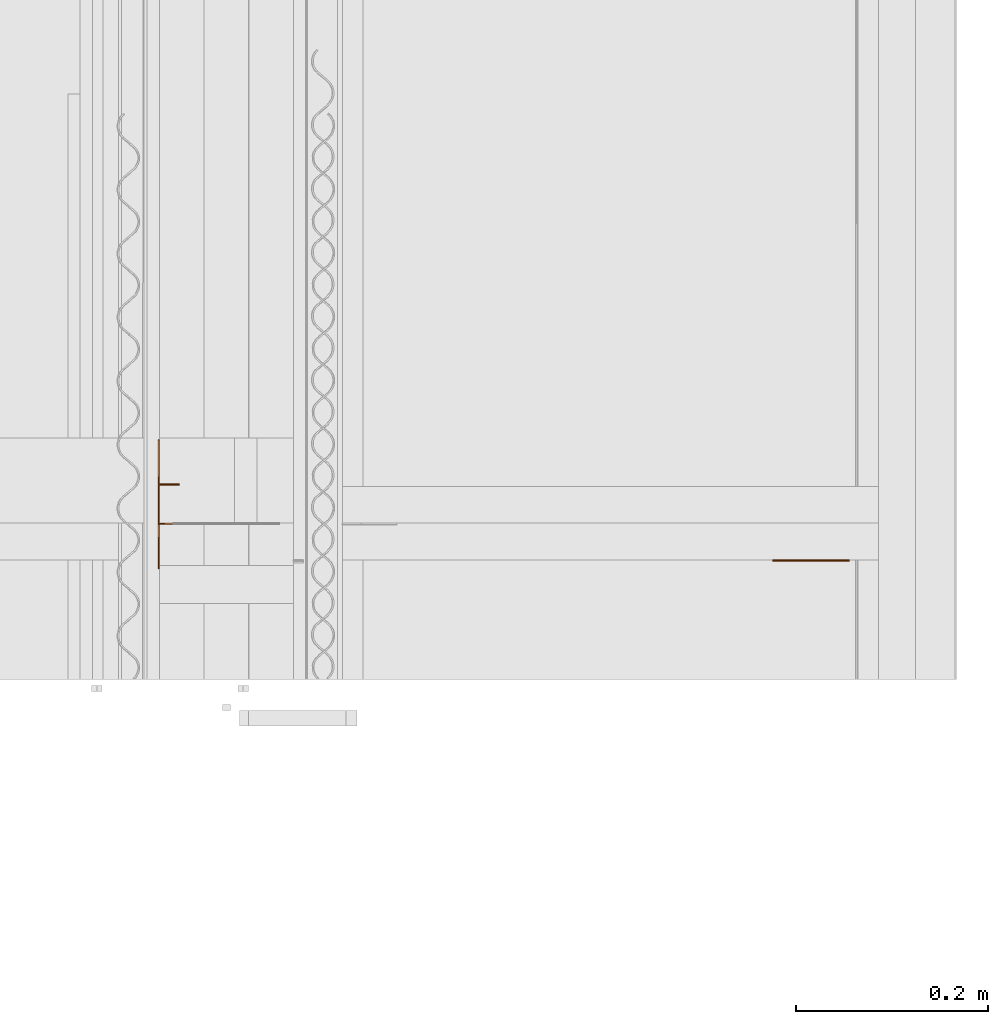
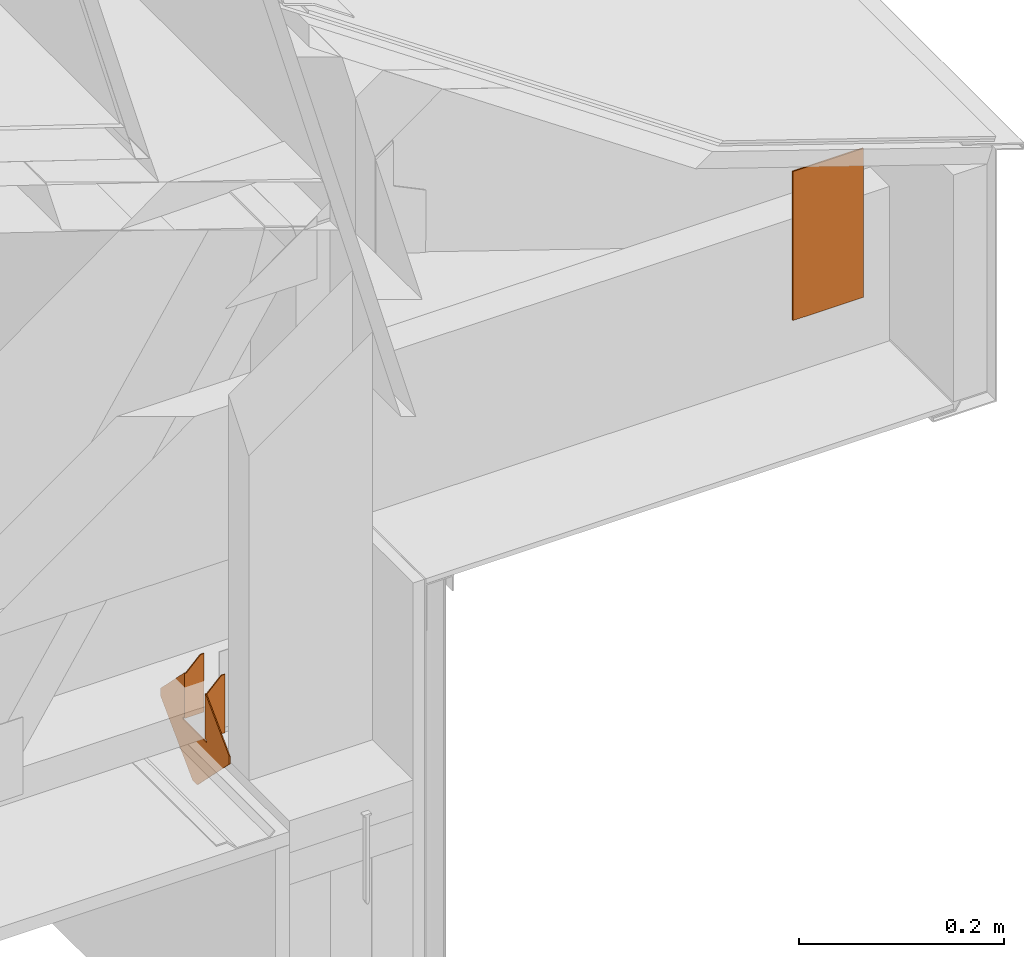
# One storey, part 21 of 22: 2 proxies.
"""IFC2X3 building model written with IfcOpenShell, lengths in feet."""

from ifc_helpers import new_model, entity, si_unit, converted_unit, frame, frame_2d, origin_with_axes, place, context, subcontext, project, spatial, faceted_brep, element, save


model = new_model("IFC2X3")

# Units and contexts
model_context = context("Model", 3, precision=1e-05)
plan_context = context("Plan", 2, precision=1e-05, world=frame_2d((0.0, 0.0, 0.0), x_axis=(1.0, 0.0, 0.0)))
body_context_1 = subcontext(model_context, "Body", "Model", "MODEL_VIEW")
body_context_2 = subcontext(model_context, "Body", "Model", "MODEL_VIEW")
ifc_project = project(units=[converted_unit("VOLUMEUNIT", "cubic foot", entity("IfcReal", 0.0283168467116885), si_unit("VOLUMEUNIT", "CUBIC_METRE"), dimensions=[3, 0, 0, 0, 0, 0, 0]), converted_unit("AREAUNIT", "square foot", entity("IfcReal", 0.09290304), si_unit("AREAUNIT", "SQUARE_METRE"), dimensions=[2, 0, 0, 0, 0, 0, 0]), converted_unit("LENGTHUNIT", "foot", entity("IfcReal", 0.3048), si_unit("LENGTHUNIT", "METRE"), dimensions=[1, 0, 0, 0, 0, 0, 0])], contexts=[model_context, plan_context])

# Site, building, storey
site_placement = place(None, origin_with_axes())
site = spatial("IfcSite", under=ifc_project, at=site_placement, CompositionType="ELEMENT")
building_placement = place(site_placement, origin_with_axes())
building = spatial("IfcBuilding", under=site, at=building_placement, Name="Building", CompositionType="ELEMENT")
storey_placement = place(building_placement, origin_with_axes())
storey = spatial("IfcBuildingStorey", under=building, at=storey_placement, Name="Storey", CompositionType="ELEMENT")

# Proxies
proxy_1_placement = place(storey_placement, frame((1615.50546881408, 2.48999811532929, -61.6529732551475), z_axis=(0.0, 0.0, 1.0), x_axis=(1.0, 0.0, 0.0)))
element("IfcBuildingElementProxy", 1, at=proxy_1_placement, inside=storey, Name="H1:H1", context=body_context_2, shape_type="Brep", body=[
    faceted_brep([(1.23378489647052e-08, -0.0757291689515114, 2.0833333110204e-05), (1.23378489647052e-08, -0.0757291689515114, 0.0104374997317791), (0.00390001223422587, -0.0757291689515114, 0.0104374997317791), (0.00390001223422587, -0.0757291689515114, 2.0833333110204e-05), (1.12442428701343e-08, -0.0690166652202606, 0.186237677931786), (3.58510376941013e-08, -0.220052093267441, 0.0352022610604763), (0.00390003598295152, -0.220052093267441, 0.0352022610604763), (0.00390001107007265, -0.0690166652202606, 0.186237677931786), (-1.23378489647052e-08, 0.0757291689515114, 0.0104374997317791), (-1.23378489647052e-08, 0.0757291689515114, 2.0833333110204e-05), (0.00389998778700829, 0.0757291689515114, 2.0833333110204e-05), (0.00389998778700829, 0.0757291689515114, 0.0104374997317791), (0.00557390507310629, -0.0690166652202606, 0.186237677931786), (0.00390001107007265, -0.0690166652202606, 0.0104374997317791), (0.0715905725955963, -0.06901665776968, 0.0104374997317791), (0.0715905725955963, -0.06901665776968, 0.23960417509079), (0.0589403994381428, -0.06901665776968, 0.23960417509079), (0.00390003598295152, -0.220052093267441, 0.00390190631151199), (0.00390000268816948, -0.0156501773744822, -0.200499996542931), (0.00389999733306468, 0.0156501773744822, -0.200499996542931), (0.00389996403828263, 0.220052093267441, 0.00390190631151199), (0.00389996403828263, 0.220052093267441, 0.0352022610604763), (0.0038999889511615, 0.0690166652202606, 0.186237677931786), (0.0038999889511615, 0.0690166652202606, 0.0104374997317791), (1.06088524631787e-08, -0.0651166662573814, 0.0104374997317791), (0.0715905725955963, -0.0651166588068008, 0.0104374997317791), (0.0715905502438545, 0.0690166801214218, 0.0104374997317791), (0.0715905502438545, 0.0690166801214218, 0.23960417509079), (0.0715905502438545, 0.0651166811585426, 0.23960417509079), (0.0715905502438545, 0.0651166811585426, 0.0104374997317791), (-3.58510376941013e-08, 0.220052093267441, 0.00390190631151199), (-3.58510376941013e-08, 0.220052093267441, 0.0352022610604763), (-1.12442428701343e-08, 0.0690166652202606, 0.186237677931786), (-1.06088524631787e-08, 0.0651166662573814, 0.186237677931786), (0.00557388365268707, 0.0651166662573814, 0.186237677931786), (0.00557388318702579, 0.0690166652202606, 0.186237677931786), (-2.54973775426492e-09, 0.0156501773744822, -0.200499996542931), (2.54973775426492e-09, -0.0156501773744822, -0.200499996542931), (0.0589403994381428, -0.0651166588068008, 0.23960417509079), (0.00557390507310629, -0.0651166662573814, 0.186237677931786), (0.0715905725955963, -0.0651166588068008, 0.23960417509079), (1.06088524631787e-08, -0.0651166662573814, 0.186237677931786), (-1.06088524631787e-08, 0.0651166662573814, 0.0104374997317791), (0.0589403733611107, 0.0651166811585426, 0.23960417509079), (0.0589403733611107, 0.0690166801214218, 0.23960417509079), (3.58510376941013e-08, -0.220052093267441, 0.00390190631151199)], [[[0, 1, 2, 3]], [[4, 5, 6, 7]], [[8, 9, 10, 11]], [[12, 7, 13, 14, 15, 16]], [[10, 3, 2, 13, 7, 6, 17, 18, 19, 20, 21, 22, 23, 11]], [[24, 25, 14, 13, 2, 1]], [[26, 27, 28, 29]], [[30, 31, 21, 20]], [[22, 32, 33, 34, 35]], [[31, 32, 22, 21]], [[0, 3, 10, 9]], [[36, 19, 18, 37]], [[12, 16, 38, 39]], [[39, 38, 40, 25, 24, 41]], [[42, 8, 11, 23, 26, 29]], [[34, 43, 44, 35]], [[40, 38, 16, 15]], [[0, 9, 8, 42, 33, 32, 31, 30, 36, 37, 45, 5, 4, 41, 24, 1]], [[39, 41, 4, 7, 12]], [[42, 29, 28, 43, 34, 33]], [[20, 19, 36, 30]], [[25, 40, 15, 14]], [[43, 28, 27, 44]], [[18, 17, 45, 37]], [[5, 45, 17, 6]], [[26, 23, 22, 35, 44, 27]]]),
])
proxy_2_placement = place(storey_placement, frame((1617.89801489963, 2.29467283396583, -60.3717768911927), z_axis=(0.0, -1.0, -4.37113882867379e-08), x_axis=(1.0, 0.0, 0.0)))
element("IfcBuildingElementProxy", 2, at=proxy_2_placement, inside=storey, Name="Plane", context=body_context_1, shape_type="Brep", body=[
    faceted_brep([(-0.291666656732559, -0.291666656732559, 0.0), (-0.0303334444761276, -0.291666656732559, -7.63880070309142e-10), (-0.0303334444761276, 0.291666656732559, -7.63880070309142e-10), (-0.291666656732559, 0.291666656732559, 0.0), (-0.291666656732559, -0.291666656732559, -0.00520833348855376), (-0.291666656732559, 0.291666656732559, -0.00520833348855376), (-0.0303334444761276, 0.291666656732559, -0.00520833302289248), (-0.0303334444761276, -0.291666656732559, -0.00520833302289248)], [[[0, 1, 2, 3]], [[4, 5, 6, 7]], [[1, 7, 6, 2]], [[3, 5, 4, 0]], [[2, 6, 5, 3]], [[0, 4, 7, 1]]]),
])

save(model, "model.ifc")
